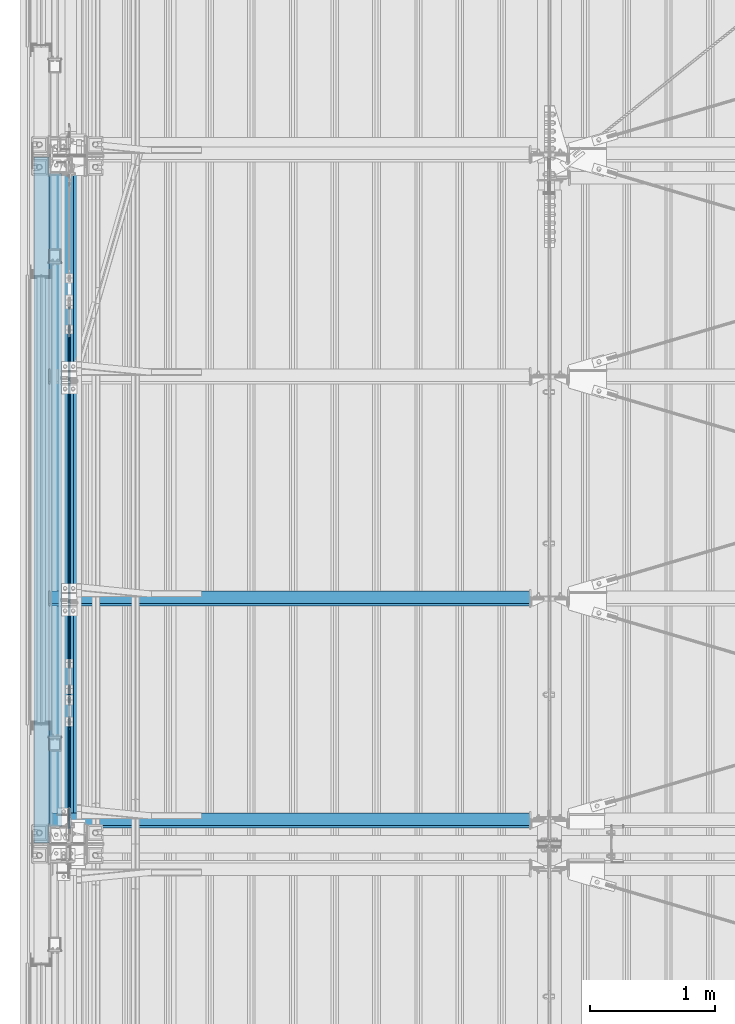
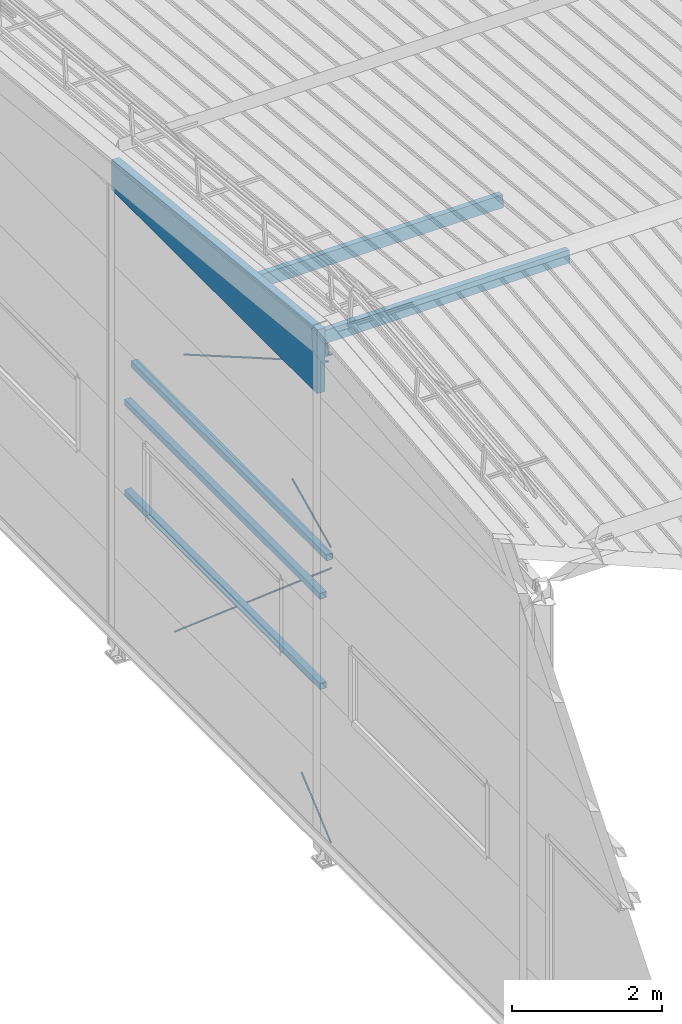
# One storey, part 247 of 709: 7 beams, 4 members, 4 openings, 11 elements without a shape of their own.
"""IFC4 building model written with IfcOpenShell, lengths in millimetres."""

from ifc_helpers import new_model, si_unit, direction, frame, origin_with_axes, place, context, subcontext, project, spatial, line, indexed_curve, outline, extrude, polygons, material, element, aggregate, save


model = new_model("IFC4")

# Units and contexts
model_context = context("Model", 3, precision=0.2, world=origin_with_axes(), true_north=direction((0.0, 1.0)))
body_context = subcontext(model_context, "Body", "Model", "MODEL_VIEW")
reference_context = subcontext(model_context, "Reference", "Model", "MODEL_VIEW")
ifc_project = project(units=[si_unit("LENGTHUNIT", "METRE", prefix="MILLI"), si_unit("AREAUNIT", "SQUARE_METRE"), si_unit("VOLUMEUNIT", "CUBIC_METRE"), si_unit("MASSUNIT", "GRAM", prefix="KILO"), si_unit("TIMEUNIT", "SECOND"), si_unit("PLANEANGLEUNIT", "RADIAN"), si_unit("SOLIDANGLEUNIT", "STERADIAN"), si_unit("THERMODYNAMICTEMPERATUREUNIT", "DEGREE_CELSIUS"), si_unit("LUMINOUSINTENSITYUNIT", "LUMEN")], contexts=[model_context])

# Site, building, storey
site_placement = place(None, origin_with_axes())
site = spatial("IfcSite", under=ifc_project, at=site_placement, CompositionType="ELEMENT")
building_placement = place(site_placement, origin_with_axes())
building = spatial("IfcBuilding", under=site, at=building_placement, Name="Undefined", CompositionType="ELEMENT")
storey_placement = place(building_placement, origin_with_axes())
storey = spatial("IfcBuildingStorey", under=building, at=storey_placement, Name="Undefined", CompositionType="ELEMENT", Elevation=0.0)

# Assembly, beam
assembly_1_placement = place(storey_placement, frame((162.5, 16500.0, 7445.307), z_axis=(-1.0, 0.0, 0.0), x_axis=(0.0, -0.9950371902, 0.099503719)))
assembly_1 = element("IfcElementAssembly", 1, at=assembly_1_placement, inside=storey)
ifc_material_1 = material(Name="C255-4", Category="STEEL")
beam_1_placement = place(assembly_1_placement, origin_with_axes())
beam_1 = element("IfcBeam", 2, at=beam_1_placement, material=ifc_material_1, ObjectType="452", context=body_context, shape_type="Tessellation", body=[
    polygons([(166.87157, -124.0, 62.0), (166.87157, -116.0, 62.0), (166.87157, -116.0, 2.5), (166.87157, 116.0, 2.5), (166.87157, 116.0, 62.0), (166.87157, 124.0, 62.0), (166.87157, 124.0, -62.0), (166.87157, 116.0, -62.0), (166.87157, 116.0, -2.5), (166.87157, -116.0, -2.5), (166.87157, -116.0, -62.0), (166.87157, -124.0, -62.0), (5323.56002, 124.0, 62.0), (5323.56002, 124.0, -62.0), (5323.56002, 116.0, -62.0), (5323.56002, 116.0, -2.5), (5323.56002, -116.0, -2.5), (5323.56002, -116.0, -62.0), (5323.56002, -124.0, -62.0), (5323.56002, -124.0, 62.0), (5323.56002, -116.0, 62.0), (5323.56002, -116.0, 2.5), (5323.56002, 116.0, 2.5), (5323.56002, 116.0, 62.0)], [[[1, 2, 3, 4, 5, 6, 7, 8, 9, 10, 11, 12]], [[7, 6, 13, 14]], [[8, 7, 14, 15]], [[9, 8, 15, 16]], [[10, 9, 16, 17]], [[11, 10, 17, 18]], [[12, 11, 18, 19]], [[1, 12, 19, 20]], [[2, 1, 20, 21]], [[3, 2, 21, 22]], [[4, 3, 22, 23]], [[5, 4, 23, 24]], [[6, 5, 24, 13]], [[23, 22, 21, 20, 19, 18, 17, 16, 15, 14, 13, 24]]], closed=True),
])
aggregate(assembly_1, [beam_1])

assembly_2_placement = place(storey_placement, frame((50.0, 16500.0, 2550.0), z_axis=(0.0, 0.0, -1.0), x_axis=(0.0, -1.0, 0.0)))
assembly_2 = element("IfcElementAssembly", 3, at=assembly_2_placement, inside=storey)
ifc_material_2 = material(Name="C355", Category="STEEL")
beam_2_placement = place(assembly_2_placement, origin_with_axes())
beam_2 = element("IfcBeam", 4, at=beam_2_placement, material=ifc_material_2, ObjectType="511", context=body_context, shape_type="Tessellation", body=[
    polygons([(142.5, -47.0, -47.0), (142.5, -47.0, 47.0), (5357.5, -47.0, 47.0), (5357.5, -47.0, -47.0), (142.5, 47.0, 47.0), (5357.5, 47.0, 47.0), (142.5, 47.0, -47.0), (5357.5, 47.0, -47.0), (142.5, -50.0, -50.0), (142.5, 50.0, -50.0), (5357.5, 50.0, -50.0), (5357.5, -50.0, -50.0), (142.5, 50.0, 50.0), (5357.5, 50.0, 50.0), (142.5, -50.0, 50.0), (5357.5, -50.0, 50.0)], [[[1, 2, 3, 4]], [[2, 5, 6, 3]], [[5, 7, 8, 6]], [[7, 1, 4, 8]], [[9, 10, 11, 12]], [[10, 13, 14, 11]], [[13, 15, 16, 14]], [[15, 9, 12, 16]], [[14, 16, 12, 11], [6, 8, 4, 3]], [[15, 13, 10, 9], [7, 5, 2, 1]]], closed=True),
])
aggregate(assembly_2, [beam_2])

assembly_3_placement = place(storey_placement, frame((50.0, 16500.0, 4020.0), z_axis=(0.0, 0.0, -1.0), x_axis=(0.0, -1.0, 0.0)))
assembly_3 = element("IfcElementAssembly", 5, at=assembly_3_placement, inside=storey)
beam_3_placement = place(assembly_3_placement, origin_with_axes())
beam_3 = element("IfcBeam", 6, at=beam_3_placement, material=ifc_material_2, ObjectType="511", context=body_context, shape_type="Tessellation", body=[
    polygons([(142.5, -47.0, -47.0), (142.5, -47.0, 47.0), (5357.5, -47.0, 47.0), (5357.5, -47.0, -47.0), (142.5, 47.0, 47.0), (5357.5, 47.0, 47.0), (142.5, 47.0, -47.0), (5357.5, 47.0, -47.0), (142.5, -50.0, -50.0), (142.5, 50.0, -50.0), (5357.5, 50.0, -50.0), (5357.5, -50.0, -50.0), (142.5, 50.0, 50.0), (5357.5, 50.0, 50.0), (142.5, -50.0, 50.0), (5357.5, -50.0, 50.0)], [[[1, 2, 3, 4]], [[2, 5, 6, 3]], [[5, 7, 8, 6]], [[7, 1, 4, 8]], [[9, 10, 11, 12]], [[10, 13, 14, 11]], [[13, 15, 16, 14]], [[15, 9, 12, 16]], [[14, 16, 12, 11], [6, 8, 4, 3]], [[15, 13, 10, 9], [7, 5, 2, 1]]], closed=True),
])
aggregate(assembly_3, [beam_3])

assembly_4_placement = place(storey_placement, frame((149.0, 16500.0, 4610.0), z_axis=(0.0, 0.0, -1.0), x_axis=(0.0, -1.0, 0.0)))
assembly_4 = element("IfcElementAssembly", 7, at=assembly_4_placement, inside=storey)
beam_4_placement = place(assembly_4_placement, origin_with_axes())
beam_4 = element("IfcBeam", 8, at=beam_4_placement, material=ifc_material_2, ObjectType="512", context=body_context, shape_type="Tessellation", body=[
    polygons([(142.5, -47.0, -47.0), (142.5, -47.0, 47.0), (5357.5, -47.0, 47.0), (5357.5, -47.0, -47.0), (142.5, 47.0, 47.0), (5357.5, 47.0, 47.0), (142.5, 47.0, -47.0), (5357.5, 47.0, -47.0), (142.5, -50.0, -50.0), (142.5, 50.0, -50.0), (5357.5, 50.0, -50.0), (5357.5, -50.0, -50.0), (142.5, 50.0, 50.0), (5357.5, 50.0, 50.0), (142.5, -50.0, 50.0), (5357.5, -50.0, 50.0)], [[[1, 2, 3, 4]], [[2, 5, 6, 3]], [[5, 7, 8, 6]], [[7, 1, 4, 8]], [[9, 10, 11, 12]], [[10, 13, 14, 11]], [[13, 15, 16, 14]], [[15, 9, 12, 16]], [[14, 16, 12, 11], [6, 8, 4, 3]], [[15, 13, 10, 9], [7, 5, 2, 1]]], closed=True),
])
aggregate(assembly_4, [beam_4])

# Assembly, member, voiding feature
assembly_5_placement = place(storey_placement, frame((165.0, 15435.54649, 754.36172), z_axis=(-1.0, 0.0, 0.0), x_axis=(0.0, -0.7603239329, 0.649544084)))
assembly_5 = element("IfcElementAssembly", 9, at=assembly_5_placement, inside=storey)
ifc_material_3 = material(Name="C355-5", Category="STEEL")
member_1_placement = place(assembly_5_placement, origin_with_axes())
member_1 = element("IfcMember", 10, at=member_1_placement, material=ifc_material_3, ObjectType="514", context=body_context, shape_type="Tessellation", body=[
    polygons([(5665.77433, -5.0, 8.66025), (5665.77433, -7.07107, 7.07107), (5665.77433, -8.66025, 5.0), (5665.77433, -9.65926, 2.58819), (5665.77433, -10.0, 0.0), (5665.77433, -9.65926, -2.58819), (5665.77433, -8.66025, -5.0), (5665.77433, -7.07107, -7.07107), (5665.77433, -5.0, -8.66025), (5665.77433, -2.58819, -9.65926), (5665.77433, 0.0, -10.0), (5665.77433, 2.58819, -9.65926), (5665.77433, 5.0, -8.66025), (5665.77433, 7.07107, -7.07107), (5665.77433, 8.66025, -5.0), (5665.77433, 9.65926, -2.58819), (5665.77433, 10.0, 0.0), (5665.77433, 9.65926, 2.58819), (5665.77433, 8.66025, 5.0), (5665.77433, 7.07107, 7.07107), (5665.77433, 5.0, 8.66025), (5665.77433, 2.58819, 9.65926), (5665.77433, 0.0, 10.0), (5665.77433, -2.58819, 9.65926), (190.0, 10.0, 0.0), (190.0, 9.65926, 2.58819), (190.0, 8.66025, 5.0), (190.0, 7.07107, 7.07107), (190.0, 5.0, 8.66025), (190.0, 2.58819, 9.65926), (190.0, 0.0, 10.0), (190.0, -2.58819, 9.65926), (190.0, -5.0, 8.66025), (190.0, -7.07107, 7.07107), (190.0, -8.66025, 5.0), (190.0, -9.65926, 2.58819), (190.0, -10.0, 0.0), (190.0, -9.65926, -2.58819), (190.0, -8.66025, -5.0), (190.0, -7.07107, -7.07107), (190.0, -5.0, -8.66025), (190.0, -2.58819, -9.65926), (190.0, 0.0, -10.0), (190.0, 2.58819, -9.65926), (190.0, 5.0, -8.66025), (190.0, 7.07107, -7.07107), (190.0, 8.66025, -5.0), (190.0, 9.65926, -2.58819), (10.0, 7.36122, 4.25), (190.0, 7.36122, 4.25), (190.0, 8.21037, 2.19996), (10.0, 8.21037, 2.19996), (10.0, 6.01041, 6.01041), (190.0, 6.01041, 6.01041), (10.0, 4.25, 7.36122), (190.0, 4.25, 7.36122), (10.0, 2.19996, 8.21037), (190.0, 2.19996, 8.21037), (10.0, 0.0, 8.5), (190.0, 0.0, 8.5), (10.0, -2.19996, 8.21037), (190.0, -2.19996, 8.21037), (10.0, -4.25, 7.36122), (190.0, -4.25, 7.36122), (10.0, -6.01041, 6.01041), (190.0, -6.01041, 6.01041), (10.0, -7.36122, 4.25), (190.0, -7.36122, 4.25), (10.0, -8.21037, 2.19996), (190.0, -8.21037, 2.19996), (10.0, -8.5, 0.0), (190.0, -8.5, 0.0), (10.0, -8.21037, -2.19996), (190.0, -8.21037, -2.19996), (10.0, -7.36122, -4.25), (190.0, -7.36122, -4.25), (10.0, -6.01041, -6.01041), (190.0, -6.01041, -6.01041), (10.0, -4.25, -7.36122), (190.0, -4.25, -7.36122), (10.0, -2.19996, -8.21037), (190.0, -2.19996, -8.21037), (10.0, 0.0, -8.5), (190.0, 0.0, -8.5), (10.0, 2.19996, -8.21037), (190.0, 2.19996, -8.21037), (10.0, 4.25, -7.36122), (190.0, 4.25, -7.36122), (10.0, 6.01041, -6.01041), (190.0, 6.01041, -6.01041), (10.0, 7.36122, -4.25), (190.0, 7.36122, -4.25), (10.0, 8.21037, -2.19996), (190.0, 8.21037, -2.19996), (10.0, 8.5, 0.0), (190.0, 8.5, 0.0)], [[[1, 2, 3, 4, 5, 6, 7, 8, 9, 10, 11, 12, 13, 14, 15, 16, 17, 18, 19, 20, 21, 22, 23, 24]], [[18, 17, 25, 26]], [[19, 18, 26, 27]], [[20, 19, 27, 28]], [[21, 20, 28, 29]], [[22, 21, 29, 30]], [[23, 22, 30, 31]], [[24, 23, 31, 32]], [[1, 24, 32, 33]], [[2, 1, 33, 34]], [[3, 2, 34, 35]], [[4, 3, 35, 36]], [[5, 4, 36, 37]], [[6, 5, 37, 38]], [[7, 6, 38, 39]], [[8, 7, 39, 40]], [[9, 8, 40, 41]], [[10, 9, 41, 42]], [[11, 10, 42, 43]], [[12, 11, 43, 44]], [[13, 12, 44, 45]], [[14, 13, 45, 46]], [[15, 14, 46, 47]], [[16, 15, 47, 48]], [[17, 16, 48, 25]], [[25, 48, 47, 46, 45, 44, 43, 42, 41, 40, 39, 38, 37, 36, 35, 34, 33, 32, 31, 30, 29, 28, 27, 26], [74, 76, 78, 80, 82, 84, 86, 88, 90, 92, 94, 96, 51, 50, 54, 56, 58, 60, 62, 64, 66, 68, 70, 72]], [[49, 50, 51, 52]], [[53, 54, 50, 49]], [[55, 56, 54, 53]], [[57, 58, 56, 55]], [[59, 60, 58, 57]], [[61, 62, 60, 59]], [[63, 64, 62, 61]], [[65, 66, 64, 63]], [[67, 68, 66, 65]], [[69, 70, 68, 67]], [[71, 72, 70, 69]], [[73, 74, 72, 71]], [[75, 76, 74, 73]], [[77, 78, 76, 75]], [[79, 80, 78, 77]], [[81, 82, 80, 79]], [[83, 84, 82, 81]], [[85, 86, 84, 83]], [[87, 88, 86, 85]], [[89, 90, 88, 87]], [[91, 92, 90, 89]], [[93, 94, 92, 91]], [[95, 96, 94, 93]], [[52, 51, 96, 95]], [[91, 89, 87, 85, 83, 81, 79, 77, 75, 73, 71, 69, 67, 65, 63, 61, 59, 57, 55, 53, 49, 52, 95, 93]]], closed=True),
])
voiding_feature_1_placement = place(member_1_placement, frame((10.0, 0.0, 0.0), z_axis=(0.0, -1.0, 0.0), x_axis=(1.0, 0.0, 0.0)))
element("IfcVoidingFeature", 11, at=voiding_feature_1_placement, cuts=member_1, PredefinedType="HOLE", context=reference_context, identifier="Reference", shape_type="SolidModel", body=[
    extrude(outline(indexed_curve([(10.5, 0.0), (10.14222, 2.7176), (9.09327, 5.25), (7.42462, 7.42462), (5.25, 9.09327), (2.7176, 10.14222), (0.0, 10.5), (-2.7176, 10.14222), (-5.25, 9.09327), (-7.42462, 7.42462), (-9.09327, 5.25), (-10.14222, 2.7176), (-10.5, 0.0), (-10.14222, -2.7176), (-9.09327, -5.25), (-7.42462, -7.42462), (-5.25, -9.09327), (-2.7176, -10.14222), (0.0, -10.5), (2.7176, -10.14222), (5.25, -9.09327), (7.42462, -7.42462), (9.09327, -5.25), (10.14222, -2.7176)], segments=[line(1, 2, 3, 4, 5, 6, 7, 8, 9, 10, 11, 12, 13, 14, 15, 16, 17, 18, 19, 20, 21, 22, 23, 24, 1)])), frame((0.0, 0.0, 0.0), z_axis=(-1.0, 0.0, 0.0), x_axis=(0.0, 0.0, 1.0)), (0.0, 0.0, -1.0), 180.0),
])
aggregate(assembly_5, [member_1])

assembly_6_placement = place(storey_placement, frame((165.0, 12064.45351, 754.36172), z_axis=(-1.0, 0.0, 0.0), x_axis=(0.0, -0.7603239329, -0.649544084)))
assembly_6 = element("IfcElementAssembly", 12, at=assembly_6_placement, inside=storey)
member_2_placement = place(assembly_6_placement, origin_with_axes())
member_2 = element("IfcMember", 13, at=member_2_placement, material=ifc_material_3, ObjectType="513", context=body_context, shape_type="Tessellation", body=[
    polygons([(1220.17807, -5.0, 8.66025), (1220.17807, -7.07107, 7.07107), (1220.17807, -8.66025, 5.0), (1220.17807, -9.65926, 2.58819), (1220.17807, -10.0, 0.0), (1220.17807, -9.65926, -2.58819), (1220.17807, -8.66025, -5.0), (1220.17807, -7.07107, -7.07107), (1220.17807, -5.0, -8.66025), (1220.17807, -2.58819, -9.65926), (1220.17807, 0.0, -10.0), (1220.17807, 2.58819, -9.65926), (1220.17807, 5.0, -8.66025), (1220.17807, 7.07107, -7.07107), (1220.17807, 8.66025, -5.0), (1220.17807, 9.65926, -2.58819), (1220.17807, 10.0, 0.0), (1220.17807, 9.65926, 2.58819), (1220.17807, 8.66025, 5.0), (1220.17807, 7.07107, 7.07107), (1220.17807, 5.0, 8.66025), (1220.17807, 2.58819, 9.65926), (1220.17807, 0.0, 10.0), (1220.17807, -2.58819, 9.65926), (190.0, 10.0, 0.0), (190.0, 9.65926, 2.58819), (190.0, 8.66025, 5.0), (190.0, 7.07107, 7.07107), (190.0, 5.0, 8.66025), (190.0, 2.58819, 9.65926), (190.0, 0.0, 10.0), (190.0, -2.58819, 9.65926), (190.0, -5.0, 8.66025), (190.0, -7.07107, 7.07107), (190.0, -8.66025, 5.0), (190.0, -9.65926, 2.58819), (190.0, -10.0, 0.0), (190.0, -9.65926, -2.58819), (190.0, -8.66025, -5.0), (190.0, -7.07107, -7.07107), (190.0, -5.0, -8.66025), (190.0, -2.58819, -9.65926), (190.0, 0.0, -10.0), (190.0, 2.58819, -9.65926), (190.0, 5.0, -8.66025), (190.0, 7.07107, -7.07107), (190.0, 8.66025, -5.0), (190.0, 9.65926, -2.58819), (10.0, 7.36122, 4.25), (190.0, 7.36122, 4.25), (190.0, 8.21037, 2.19996), (10.0, 8.21037, 2.19996), (10.0, 6.01041, 6.01041), (190.0, 6.01041, 6.01041), (10.0, 4.25, 7.36122), (190.0, 4.25, 7.36122), (10.0, 2.19996, 8.21037), (190.0, 2.19996, 8.21037), (10.0, 0.0, 8.5), (190.0, 0.0, 8.5), (10.0, -2.19996, 8.21037), (190.0, -2.19996, 8.21037), (10.0, -4.25, 7.36122), (190.0, -4.25, 7.36122), (10.0, -6.01041, 6.01041), (190.0, -6.01041, 6.01041), (10.0, -7.36122, 4.25), (190.0, -7.36122, 4.25), (10.0, -8.21037, 2.19996), (190.0, -8.21037, 2.19996), (10.0, -8.5, 0.0), (190.0, -8.5, 0.0), (10.0, -8.21037, -2.19996), (190.0, -8.21037, -2.19996), (10.0, -7.36122, -4.25), (190.0, -7.36122, -4.25), (10.0, -6.01041, -6.01041), (190.0, -6.01041, -6.01041), (10.0, -4.25, -7.36122), (190.0, -4.25, -7.36122), (10.0, -2.19996, -8.21037), (190.0, -2.19996, -8.21037), (10.0, 0.0, -8.5), (190.0, 0.0, -8.5), (10.0, 2.19996, -8.21037), (190.0, 2.19996, -8.21037), (10.0, 4.25, -7.36122), (190.0, 4.25, -7.36122), (10.0, 6.01041, -6.01041), (190.0, 6.01041, -6.01041), (10.0, 7.36122, -4.25), (190.0, 7.36122, -4.25), (10.0, 8.21037, -2.19996), (190.0, 8.21037, -2.19996), (10.0, 8.5, 0.0), (190.0, 8.5, 0.0)], [[[1, 2, 3, 4, 5, 6, 7, 8, 9, 10, 11, 12, 13, 14, 15, 16, 17, 18, 19, 20, 21, 22, 23, 24]], [[18, 17, 25, 26]], [[19, 18, 26, 27]], [[20, 19, 27, 28]], [[21, 20, 28, 29]], [[22, 21, 29, 30]], [[23, 22, 30, 31]], [[24, 23, 31, 32]], [[1, 24, 32, 33]], [[2, 1, 33, 34]], [[3, 2, 34, 35]], [[4, 3, 35, 36]], [[5, 4, 36, 37]], [[6, 5, 37, 38]], [[7, 6, 38, 39]], [[8, 7, 39, 40]], [[9, 8, 40, 41]], [[10, 9, 41, 42]], [[11, 10, 42, 43]], [[12, 11, 43, 44]], [[13, 12, 44, 45]], [[14, 13, 45, 46]], [[15, 14, 46, 47]], [[16, 15, 47, 48]], [[17, 16, 48, 25]], [[25, 48, 47, 46, 45, 44, 43, 42, 41, 40, 39, 38, 37, 36, 35, 34, 33, 32, 31, 30, 29, 28, 27, 26], [74, 76, 78, 80, 82, 84, 86, 88, 90, 92, 94, 96, 51, 50, 54, 56, 58, 60, 62, 64, 66, 68, 70, 72]], [[49, 50, 51, 52]], [[53, 54, 50, 49]], [[55, 56, 54, 53]], [[57, 58, 56, 55]], [[59, 60, 58, 57]], [[61, 62, 60, 59]], [[63, 64, 62, 61]], [[65, 66, 64, 63]], [[67, 68, 66, 65]], [[69, 70, 68, 67]], [[71, 72, 70, 69]], [[73, 74, 72, 71]], [[75, 76, 74, 73]], [[77, 78, 76, 75]], [[79, 80, 78, 77]], [[81, 82, 80, 79]], [[83, 84, 82, 81]], [[85, 86, 84, 83]], [[87, 88, 86, 85]], [[89, 90, 88, 87]], [[91, 92, 90, 89]], [[93, 94, 92, 91]], [[95, 96, 94, 93]], [[52, 51, 96, 95]], [[91, 89, 87, 85, 83, 81, 79, 77, 75, 73, 71, 69, 67, 65, 63, 61, 59, 57, 55, 53, 49, 52, 95, 93]]], closed=True),
])
voiding_feature_2_placement = place(member_2_placement, frame((10.0, 0.0, 0.0), z_axis=(0.0, -1.0, 0.0), x_axis=(1.0, 0.0, 0.0)))
element("IfcVoidingFeature", 14, at=voiding_feature_2_placement, cuts=member_2, PredefinedType="HOLE", context=reference_context, identifier="Reference", shape_type="SolidModel", body=[
    extrude(outline(indexed_curve([(10.5, 0.0), (10.14222, 2.7176), (9.09327, 5.25), (7.42462, 7.42462), (5.25, 9.09327), (2.7176, 10.14222), (0.0, 10.5), (-2.7176, 10.14222), (-5.25, 9.09327), (-7.42462, 7.42462), (-9.09327, 5.25), (-10.14222, 2.7176), (-10.5, 0.0), (-10.14222, -2.7176), (-9.09327, -5.25), (-7.42462, -7.42462), (-5.25, -9.09327), (-2.7176, -10.14222), (0.0, -10.5), (2.7176, -10.14222), (5.25, -9.09327), (7.42462, -7.42462), (9.09327, -5.25), (10.14222, -2.7176)], segments=[line(1, 2, 3, 4, 5, 6, 7, 8, 9, 10, 11, 12, 13, 14, 15, 16, 17, 18, 19, 20, 21, 22, 23, 24, 1)])), frame((0.0, 0.0, 0.0), z_axis=(-1.0, 0.0, 0.0), x_axis=(0.0, 0.0, 1.0)), (0.0, 0.0, -1.0), 180.0),
])
aggregate(assembly_6, [member_2])

assembly_7_placement = place(storey_placement, frame((165.0, 15212.89749, 5439.71077), z_axis=(-1.0, 0.0, 0.0), x_axis=(0.0, -0.866144648, 0.499793406)))
assembly_7 = element("IfcElementAssembly", 15, at=assembly_7_placement, inside=storey)
member_3_placement = place(assembly_7_placement, origin_with_axes())
member_3 = element("IfcMember", 16, at=member_3_placement, material=ifc_material_3, ObjectType="516", context=body_context, shape_type="Tessellation", body=[
    polygons([(4623.87607, -5.0, 8.66025), (4623.87607, -7.07107, 7.07107), (4623.87607, -8.66025, 5.0), (4623.87607, -9.65926, 2.58819), (4623.87607, -10.0, 0.0), (4623.87607, -9.65926, -2.58819), (4623.87607, -8.66025, -5.0), (4623.87607, -7.07107, -7.07107), (4623.87607, -5.0, -8.66025), (4623.87607, -2.58819, -9.65926), (4623.87607, 0.0, -10.0), (4623.87607, 2.58819, -9.65926), (4623.87607, 5.0, -8.66025), (4623.87607, 7.07107, -7.07107), (4623.87607, 8.66025, -5.0), (4623.87607, 9.65926, -2.58819), (4623.87607, 10.0, 0.0), (4623.87607, 9.65926, 2.58819), (4623.87607, 8.66025, 5.0), (4623.87607, 7.07107, 7.07107), (4623.87607, 5.0, 8.66025), (4623.87607, 2.58819, 9.65926), (4623.87607, 0.0, 10.0), (4623.87607, -2.58819, 9.65926), (190.0, 10.0, 0.0), (190.0, 9.65926, 2.58819), (190.0, 8.66025, 5.0), (190.0, 7.07107, 7.07107), (190.0, 5.0, 8.66025), (190.0, 2.58819, 9.65926), (190.0, 0.0, 10.0), (190.0, -2.58819, 9.65926), (190.0, -5.0, 8.66025), (190.0, -7.07107, 7.07107), (190.0, -8.66025, 5.0), (190.0, -9.65926, 2.58819), (190.0, -10.0, 0.0), (190.0, -9.65926, -2.58819), (190.0, -8.66025, -5.0), (190.0, -7.07107, -7.07107), (190.0, -5.0, -8.66025), (190.0, -2.58819, -9.65926), (190.0, 0.0, -10.0), (190.0, 2.58819, -9.65926), (190.0, 5.0, -8.66025), (190.0, 7.07107, -7.07107), (190.0, 8.66025, -5.0), (190.0, 9.65926, -2.58819), (10.0, 7.36122, 4.25), (190.0, 7.36122, 4.25), (190.0, 8.21037, 2.19996), (10.0, 8.21037, 2.19996), (10.0, 6.01041, 6.01041), (190.0, 6.01041, 6.01041), (10.0, 4.25, 7.36122), (190.0, 4.25, 7.36122), (10.0, 2.19996, 8.21037), (190.0, 2.19996, 8.21037), (10.0, 0.0, 8.5), (190.0, 0.0, 8.5), (10.0, -2.19996, 8.21037), (190.0, -2.19996, 8.21037), (10.0, -4.25, 7.36122), (190.0, -4.25, 7.36122), (10.0, -6.01041, 6.01041), (190.0, -6.01041, 6.01041), (10.0, -7.36122, 4.25), (190.0, -7.36122, 4.25), (10.0, -8.21037, 2.19996), (190.0, -8.21037, 2.19996), (10.0, -8.5, 0.0), (190.0, -8.5, 0.0), (10.0, -8.21037, -2.19996), (190.0, -8.21037, -2.19996), (10.0, -7.36122, -4.25), (190.0, -7.36122, -4.25), (10.0, -6.01041, -6.01041), (190.0, -6.01041, -6.01041), (10.0, -4.25, -7.36122), (190.0, -4.25, -7.36122), (10.0, -2.19996, -8.21037), (190.0, -2.19996, -8.21037), (10.0, 0.0, -8.5), (190.0, 0.0, -8.5), (10.0, 2.19996, -8.21037), (190.0, 2.19996, -8.21037), (10.0, 4.25, -7.36122), (190.0, 4.25, -7.36122), (10.0, 6.01041, -6.01041), (190.0, 6.01041, -6.01041), (10.0, 7.36122, -4.25), (190.0, 7.36122, -4.25), (10.0, 8.21037, -2.19996), (190.0, 8.21037, -2.19996), (10.0, 8.5, 0.0), (190.0, 8.5, 0.0)], [[[1, 2, 3, 4, 5, 6, 7, 8, 9, 10, 11, 12, 13, 14, 15, 16, 17, 18, 19, 20, 21, 22, 23, 24]], [[18, 17, 25, 26]], [[19, 18, 26, 27]], [[20, 19, 27, 28]], [[21, 20, 28, 29]], [[22, 21, 29, 30]], [[23, 22, 30, 31]], [[24, 23, 31, 32]], [[1, 24, 32, 33]], [[2, 1, 33, 34]], [[3, 2, 34, 35]], [[4, 3, 35, 36]], [[5, 4, 36, 37]], [[6, 5, 37, 38]], [[7, 6, 38, 39]], [[8, 7, 39, 40]], [[9, 8, 40, 41]], [[10, 9, 41, 42]], [[11, 10, 42, 43]], [[12, 11, 43, 44]], [[13, 12, 44, 45]], [[14, 13, 45, 46]], [[15, 14, 46, 47]], [[16, 15, 47, 48]], [[17, 16, 48, 25]], [[25, 48, 47, 46, 45, 44, 43, 42, 41, 40, 39, 38, 37, 36, 35, 34, 33, 32, 31, 30, 29, 28, 27, 26], [74, 76, 78, 80, 82, 84, 86, 88, 90, 92, 94, 96, 51, 50, 54, 56, 58, 60, 62, 64, 66, 68, 70, 72]], [[49, 50, 51, 52]], [[53, 54, 50, 49]], [[55, 56, 54, 53]], [[57, 58, 56, 55]], [[59, 60, 58, 57]], [[61, 62, 60, 59]], [[63, 64, 62, 61]], [[65, 66, 64, 63]], [[67, 68, 66, 65]], [[69, 70, 68, 67]], [[71, 72, 70, 69]], [[73, 74, 72, 71]], [[75, 76, 74, 73]], [[77, 78, 76, 75]], [[79, 80, 78, 77]], [[81, 82, 80, 79]], [[83, 84, 82, 81]], [[85, 86, 84, 83]], [[87, 88, 86, 85]], [[89, 90, 88, 87]], [[91, 92, 90, 89]], [[93, 94, 92, 91]], [[95, 96, 94, 93]], [[52, 51, 96, 95]], [[91, 89, 87, 85, 83, 81, 79, 77, 75, 73, 71, 69, 67, 65, 63, 61, 59, 57, 55, 53, 49, 52, 95, 93]]], closed=True),
])
voiding_feature_3_placement = place(member_3_placement, frame((10.0, 0.0, 0.0), z_axis=(0.0, -1.0, 0.0), x_axis=(1.0, 0.0, 0.0)))
element("IfcVoidingFeature", 17, at=voiding_feature_3_placement, cuts=member_3, PredefinedType="HOLE", context=reference_context, identifier="Reference", shape_type="SolidModel", body=[
    extrude(outline(indexed_curve([(10.5, 0.0), (10.14222, 2.7176), (9.09327, 5.25), (7.42462, 7.42462), (5.25, 9.09327), (2.7176, 10.14222), (0.0, 10.5), (-2.7176, 10.14222), (-5.25, 9.09327), (-7.42462, 7.42462), (-9.09327, 5.25), (-10.14222, 2.7176), (-10.5, 0.0), (-10.14222, -2.7176), (-9.09327, -5.25), (-7.42462, -7.42462), (-5.25, -9.09327), (-2.7176, -10.14222), (0.0, -10.5), (2.7176, -10.14222), (5.25, -9.09327), (7.42462, -7.42462), (9.09327, -5.25), (10.14222, -2.7176)], segments=[line(1, 2, 3, 4, 5, 6, 7, 8, 9, 10, 11, 12, 13, 14, 15, 16, 17, 18, 19, 20, 21, 22, 23, 24, 1)])), frame((0.0, 0.0, 0.0), z_axis=(-1.0, 0.0, 0.0), x_axis=(0.0, 0.0, 1.0)), (0.0, 0.0, -1.0), 180.0),
])
aggregate(assembly_7, [member_3])

assembly_8_placement = place(storey_placement, frame((165.0, 12338.76537, 5341.35935), z_axis=(-1.0, 0.0, 0.0), x_axis=(0.0, -0.9030466941, -0.429542394)))
assembly_8 = element("IfcElementAssembly", 18, at=assembly_8_placement, inside=storey)
member_4_placement = place(assembly_8_placement, origin_with_axes())
member_4 = element("IfcMember", 19, at=member_4_placement, material=ifc_material_3, ObjectType="515", context=body_context, shape_type="Tessellation", body=[
    polygons([(1330.0, -5.0, 8.66025), (1330.0, -7.07107, 7.07107), (1330.0, -8.66025, 5.0), (1330.0, -9.65926, 2.58819), (1330.0, -10.0, 0.0), (1330.0, -9.65926, -2.58819), (1330.0, -8.66025, -5.0), (1330.0, -7.07107, -7.07107), (1330.0, -5.0, -8.66025), (1330.0, -2.58819, -9.65926), (1330.0, 0.0, -10.0), (1330.0, 2.58819, -9.65926), (1330.0, 5.0, -8.66025), (1330.0, 7.07107, -7.07107), (1330.0, 8.66025, -5.0), (1330.0, 9.65926, -2.58819), (1330.0, 10.0, 0.0), (1330.0, 9.65926, 2.58819), (1330.0, 8.66025, 5.0), (1330.0, 7.07107, 7.07107), (1330.0, 5.0, 8.66025), (1330.0, 2.58819, 9.65926), (1330.0, 0.0, 10.0), (1330.0, -2.58819, 9.65926), (190.0, 10.0, 0.0), (190.0, 9.65926, 2.58819), (190.0, 8.66025, 5.0), (190.0, 7.07107, 7.07107), (190.0, 5.0, 8.66025), (190.0, 2.58819, 9.65926), (190.0, 0.0, 10.0), (190.0, -2.58819, 9.65926), (190.0, -5.0, 8.66025), (190.0, -7.07107, 7.07107), (190.0, -8.66025, 5.0), (190.0, -9.65926, 2.58819), (190.0, -10.0, 0.0), (190.0, -9.65926, -2.58819), (190.0, -8.66025, -5.0), (190.0, -7.07107, -7.07107), (190.0, -5.0, -8.66025), (190.0, -2.58819, -9.65926), (190.0, 0.0, -10.0), (190.0, 2.58819, -9.65926), (190.0, 5.0, -8.66025), (190.0, 7.07107, -7.07107), (190.0, 8.66025, -5.0), (190.0, 9.65926, -2.58819), (10.0, 7.36122, 4.25), (190.0, 7.36122, 4.25), (190.0, 8.21037, 2.19996), (10.0, 8.21037, 2.19996), (10.0, 6.01041, 6.01041), (190.0, 6.01041, 6.01041), (10.0, 4.25, 7.36122), (190.0, 4.25, 7.36122), (10.0, 2.19996, 8.21037), (190.0, 2.19996, 8.21037), (10.0, 0.0, 8.5), (190.0, 0.0, 8.5), (10.0, -2.19996, 8.21037), (190.0, -2.19996, 8.21037), (10.0, -4.25, 7.36122), (190.0, -4.25, 7.36122), (10.0, -6.01041, 6.01041), (190.0, -6.01041, 6.01041), (10.0, -7.36122, 4.25), (190.0, -7.36122, 4.25), (10.0, -8.21037, 2.19996), (190.0, -8.21037, 2.19996), (10.0, -8.5, 0.0), (190.0, -8.5, 0.0), (10.0, -8.21037, -2.19996), (190.0, -8.21037, -2.19996), (10.0, -7.36122, -4.25), (190.0, -7.36122, -4.25), (10.0, -6.01041, -6.01041), (190.0, -6.01041, -6.01041), (10.0, -4.25, -7.36122), (190.0, -4.25, -7.36122), (10.0, -2.19996, -8.21037), (190.0, -2.19996, -8.21037), (10.0, 0.0, -8.5), (190.0, 0.0, -8.5), (10.0, 2.19996, -8.21037), (190.0, 2.19996, -8.21037), (10.0, 4.25, -7.36122), (190.0, 4.25, -7.36122), (10.0, 6.01041, -6.01041), (190.0, 6.01041, -6.01041), (10.0, 7.36122, -4.25), (190.0, 7.36122, -4.25), (10.0, 8.21037, -2.19996), (190.0, 8.21037, -2.19996), (10.0, 8.5, 0.0), (190.0, 8.5, 0.0)], [[[1, 2, 3, 4, 5, 6, 7, 8, 9, 10, 11, 12, 13, 14, 15, 16, 17, 18, 19, 20, 21, 22, 23, 24]], [[18, 17, 25, 26]], [[19, 18, 26, 27]], [[20, 19, 27, 28]], [[21, 20, 28, 29]], [[22, 21, 29, 30]], [[23, 22, 30, 31]], [[24, 23, 31, 32]], [[1, 24, 32, 33]], [[2, 1, 33, 34]], [[3, 2, 34, 35]], [[4, 3, 35, 36]], [[5, 4, 36, 37]], [[6, 5, 37, 38]], [[7, 6, 38, 39]], [[8, 7, 39, 40]], [[9, 8, 40, 41]], [[10, 9, 41, 42]], [[11, 10, 42, 43]], [[12, 11, 43, 44]], [[13, 12, 44, 45]], [[14, 13, 45, 46]], [[15, 14, 46, 47]], [[16, 15, 47, 48]], [[17, 16, 48, 25]], [[25, 48, 47, 46, 45, 44, 43, 42, 41, 40, 39, 38, 37, 36, 35, 34, 33, 32, 31, 30, 29, 28, 27, 26], [74, 76, 78, 80, 82, 84, 86, 88, 90, 92, 94, 96, 51, 50, 54, 56, 58, 60, 62, 64, 66, 68, 70, 72]], [[49, 50, 51, 52]], [[53, 54, 50, 49]], [[55, 56, 54, 53]], [[57, 58, 56, 55]], [[59, 60, 58, 57]], [[61, 62, 60, 59]], [[63, 64, 62, 61]], [[65, 66, 64, 63]], [[67, 68, 66, 65]], [[69, 70, 68, 67]], [[71, 72, 70, 69]], [[73, 74, 72, 71]], [[75, 76, 74, 73]], [[77, 78, 76, 75]], [[79, 80, 78, 77]], [[81, 82, 80, 79]], [[83, 84, 82, 81]], [[85, 86, 84, 83]], [[87, 88, 86, 85]], [[89, 90, 88, 87]], [[91, 92, 90, 89]], [[93, 94, 92, 91]], [[95, 96, 94, 93]], [[52, 51, 96, 95]], [[91, 89, 87, 85, 83, 81, 79, 77, 75, 73, 71, 69, 67, 65, 63, 61, 59, 57, 55, 53, 49, 52, 95, 93]]], closed=True),
])
voiding_feature_4_placement = place(member_4_placement, frame((10.0, 0.0, 0.0), z_axis=(0.0, -1.0, 0.0), x_axis=(1.0, 0.0, 0.0)))
element("IfcVoidingFeature", 20, at=voiding_feature_4_placement, cuts=member_4, PredefinedType="HOLE", context=reference_context, identifier="Reference", shape_type="SolidModel", body=[
    extrude(outline(indexed_curve([(10.5, 0.0), (10.14222, 2.7176), (9.09327, 5.25), (7.42462, 7.42462), (5.25, 9.09327), (2.7176, 10.14222), (0.0, 10.5), (-2.7176, 10.14222), (-5.25, 9.09327), (-7.42462, 7.42462), (-9.09327, 5.25), (-10.14222, 2.7176), (-10.5, 0.0), (-10.14222, -2.7176), (-9.09327, -5.25), (-7.42462, -7.42462), (-5.25, -9.09327), (-2.7176, -10.14222), (0.0, -10.5), (2.7176, -10.14222), (5.25, -9.09327), (7.42462, -7.42462), (9.09327, -5.25), (10.14222, -2.7176)], segments=[line(1, 2, 3, 4, 5, 6, 7, 8, 9, 10, 11, 12, 13, 14, 15, 16, 17, 18, 19, 20, 21, 22, 23, 24, 1)])), frame((0.0, 0.0, 0.0), z_axis=(-1.0, 0.0, 0.0), x_axis=(0.0, 0.0, 1.0)), (0.0, 0.0, -1.0), 180.0),
])
aggregate(assembly_8, [member_4])

# Assembly, beam
assembly_9_placement = place(storey_placement, frame((4000.0, 11190.04963, 8209.41925), z_axis=(0.0, -0.9950371902, 0.099503719), x_axis=(-1.0, 0.0, 0.0)))
assembly_9 = element("IfcElementAssembly", 21, at=assembly_9_placement, inside=storey)
beam_5_placement = place(assembly_9_placement, origin_with_axes())
beam_5 = element("IfcBeam", 22, at=beam_5_placement, material=ifc_material_2, ObjectType="564", context=body_context, shape_type="Tessellation", body=[
    polygons([(155.0, -100.0, 50.0), (155.0, -100.0, -50.0), (3972.0, -100.0, -50.0), (3972.0, -100.0, 50.0), (155.0, 100.0, 50.0), (3972.0, 100.0, 50.0), (155.0, 100.0, -50.0), (3972.0, 100.0, -50.0), (155.0, -96.0, 46.0), (155.0, 96.0, 46.0), (3972.0, 96.0, 46.0), (3972.0, -96.0, 46.0), (155.0, -96.0, -46.0), (3972.0, -96.0, -46.0), (155.0, 96.0, -46.0), (3972.0, 96.0, -46.0)], [[[1, 2, 3, 4]], [[5, 1, 4, 6]], [[7, 5, 6, 8]], [[2, 7, 8, 3]], [[1, 5, 7, 2], [15, 10, 9, 13]], [[9, 10, 11, 12]], [[13, 9, 12, 14]], [[15, 13, 14, 16]], [[10, 15, 16, 11]], [[3, 8, 6, 4], [14, 12, 11, 16]]], closed=True),
])
aggregate(assembly_9, [beam_5])

assembly_10_placement = place(storey_placement, frame((4000.0, 12963.34988, 8032.08923), z_axis=(0.0, -0.9950371902, 0.099503719), x_axis=(-1.0, 0.0, 0.0)))
assembly_10 = element("IfcElementAssembly", 23, at=assembly_10_placement, inside=storey)
beam_6_placement = place(assembly_10_placement, origin_with_axes())
beam_6 = element("IfcBeam", 24, at=beam_6_placement, material=ifc_material_2, ObjectType="563", context=body_context, shape_type="Tessellation", body=[
    polygons([(155.0, -100.0, 50.0), (155.0, -100.0, -50.0), (3992.0, -100.0, -50.0), (3992.0, -100.0, 50.0), (155.0, 100.0, 50.0), (3992.0, 100.0, 50.0), (155.0, 100.0, -50.0), (3992.0, 100.0, -50.0), (155.0, -96.0, 46.0), (155.0, 96.0, 46.0), (3992.0, 96.0, 46.0), (3992.0, -96.0, 46.0), (155.0, -96.0, -46.0), (3992.0, -96.0, -46.0), (155.0, 96.0, -46.0), (3992.0, 96.0, -46.0)], [[[1, 2, 3, 4]], [[5, 1, 4, 6]], [[7, 5, 6, 8]], [[2, 7, 8, 3]], [[1, 5, 7, 2], [15, 10, 9, 13]], [[9, 10, 11, 12]], [[13, 9, 12, 14]], [[15, 13, 14, 16]], [[10, 15, 16, 11]], [[3, 8, 6, 4], [14, 12, 11, 16]]], closed=True),
])
aggregate(assembly_10, [beam_6])

assembly_11_placement = place(storey_placement, frame((-60.0, 11010.0, 8035.0), z_axis=(0.0, 0.0, -1.0), x_axis=(0.0, 1.0, 0.0)))
assembly_11 = element("IfcElementAssembly", 25, at=assembly_11_placement, inside=storey)
ifc_material_4 = material(Name="Insulation", Category="Insulation")
beam_7_placement = place(assembly_11_placement, origin_with_axes())
beam_7 = element("IfcBeam", 26, at=beam_7_placement, material=ifc_material_4, ObjectType="P-136", context=body_context, shape_type="Tessellation", body=[
    polygons([(0.0, 60.0, 595.0), (0.0, -60.0, 595.0), (5480.0, -60.0, 595.0), (5480.0, 60.0, 595.0), (5480.0, 60.0, 104.329), (0.0, 60.0, -443.671), (0.0, -60.0, -443.671), (5480.0, -60.0, 104.329)], [[[1, 2, 3, 4]], [[1, 4, 5, 6]], [[2, 1, 6, 7]], [[3, 2, 7, 8]], [[4, 3, 8, 5]], [[7, 6, 5, 8]]], closed=True),
])
aggregate(assembly_11, [beam_7])

save(model, "model.ifc")
